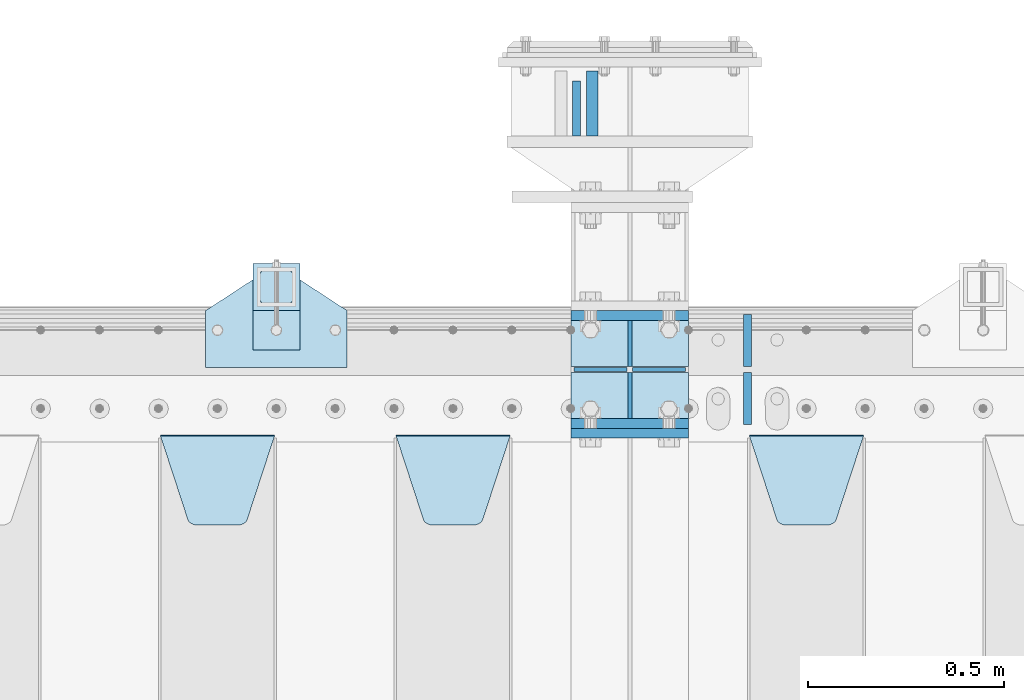
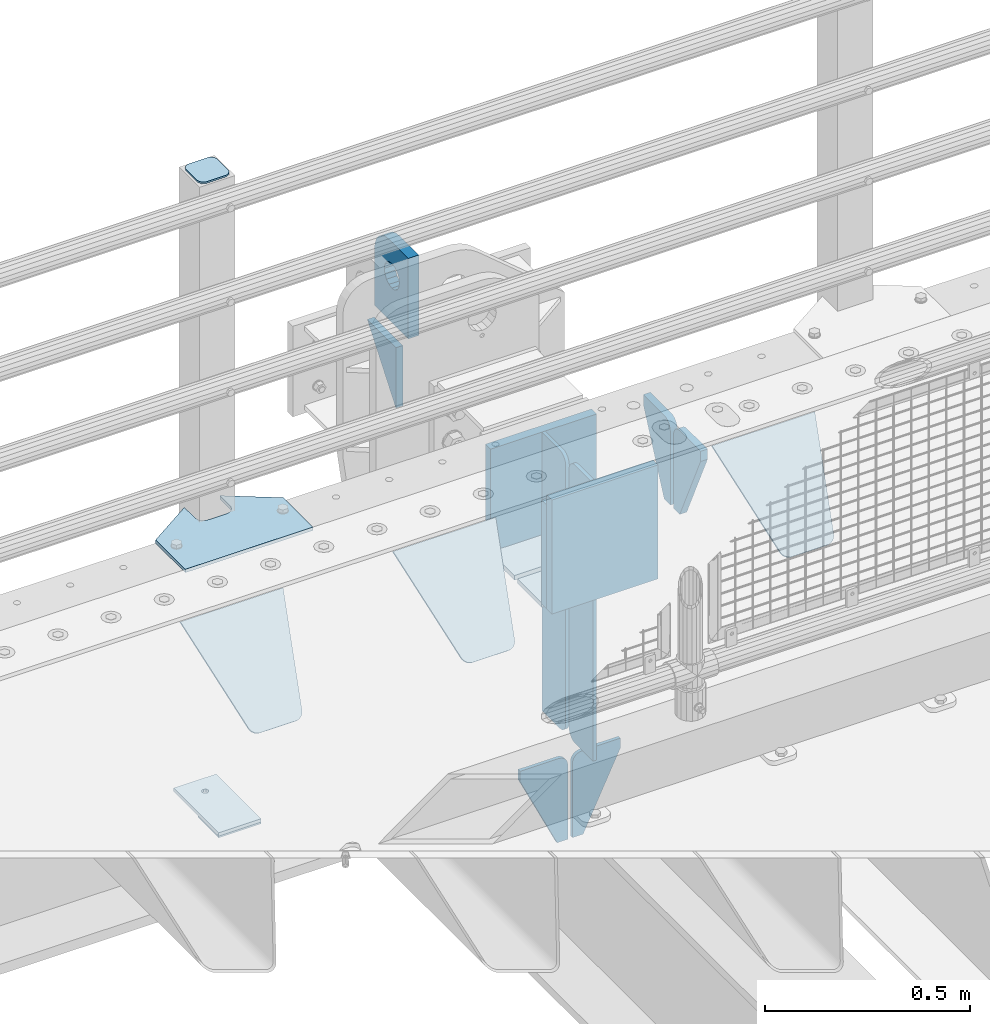
# One storey, part 231 of 257: 22 plates.
"""IFC2X3 building model written with IfcOpenShell, lengths in millimetres."""

from ifc_helpers import new_model, si_unit, frame, origin_with_axes, place, context, subcontext, project, spatial, faceted_brep, material, type_object, element, save


model = new_model("IFC2X3")

# Units and contexts
model_context = context("Model", 3, precision=1e-05, world=origin_with_axes())
body_context = subcontext(model_context, "Body", "Model", "MODEL_VIEW")
ifc_project = project(units=[si_unit("LENGTHUNIT", "METRE", prefix="MILLI"), si_unit("AREAUNIT", "SQUARE_METRE"), si_unit("VOLUMEUNIT", "CUBIC_METRE"), si_unit("MASSUNIT", "GRAM", prefix="KILO"), si_unit("TIMEUNIT", "SECOND"), si_unit("PLANEANGLEUNIT", "RADIAN"), si_unit("SOLIDANGLEUNIT", "STERADIAN"), si_unit("THERMODYNAMICTEMPERATUREUNIT", "DEGREE_CELSIUS"), si_unit("LUMINOUSINTENSITYUNIT", "LUMEN")], contexts=[model_context])

# Site, building, storey
site_placement = place(None, origin_with_axes())
site = spatial("IfcSite", under=ifc_project, at=site_placement, CompositionType="ELEMENT")
building_placement = place(site_placement, origin_with_axes())
building = spatial("IfcBuilding", under=site, at=building_placement, Name="Standard", CompositionType="ELEMENT")
storey_placement = place(building_placement, origin_with_axes())
storey = spatial("IfcBuildingStorey", under=building, at=storey_placement, Name="Undefined", CompositionType="ELEMENT", Elevation=0.0)

# Plates
ifc_material_1 = material(Name="STEEL/S355N")
plate_type_1 = type_object("IfcPlateType", PredefinedType="NOTDEFINED")
plate_1_placement = place(storey_placement, frame((54564.5000000687, 12735.0000000407, -14.0000195365101), z_axis=(0.0, 0.0, -1.0), x_axis=(0.0, -1.0, 0.0)))
element("IfcPlate", 1, at=plate_1_placement, inside=storey, type_object=plate_type_1, material=ifc_material_1, context=body_context, shape_type="Brep", body=[
    faceted_brep([(0.0, -10.0, 0.0), (140.0, -10.0, 180.0), (140.0, 10.0, 180.0), (0.0, 10.0, 0.0), (140.0, -10.0, -1.81898940354586e-12), (140.0, 10.0, -1.81898940354586e-12)], [[[0, 1, 2, 3]], [[1, 4, 5, 2]], [[4, 0, 3, 5]], [[5, 3, 2]], [[4, 1, 0]]]),
])
plate_type_2 = type_object("IfcPlateType", PredefinedType="NOTDEFINED")
plate_2_placement = place(storey_placement, frame((54604.500000067, 12595.0000000406, -1.95365428226069e-05), z_axis=(0.0, 1.0, 0.0), x_axis=(0.0, 0.0, 1.0)))
element("IfcPlate", 2, at=plate_2_placement, inside=storey, type_object=plate_type_2, material=ifc_material_1, context=body_context, shape_type="Brep", body=[
    faceted_brep([(125.840713002475, 15.0000005560505, 114.183542552877), (125.840713002475, -14.9999994439495, 114.183542852878), (113.837049096081, -14.9999995241524, 106.162951053862), (113.837049096081, 15.0000004758476, 106.162950753862), (105.816457297066, -14.9999996441911, 94.1592871474677), (105.816457297066, 15.0000003558089, 94.1592868474672), (102.999999999984, -14.9999997857813, 80.0000001499593), (102.999999999984, 15.0000002142187, 79.9999998499588), (105.816457297066, -14.9999999273787, 65.8407131524509), (105.816457297066, 15.0000000726213, 65.8407128524505), (113.837049096081, -15.0000000474101, 53.8370492460563), (113.837049096081, 14.9999999525899, 53.8370489460558), (125.840713002475, -15.0000001276203, 45.8164574470411), (125.840713002475, 14.9999998723797, 45.8164571470406), (139.999999999984, -15.0000001557855, 43.0000001499593), (139.999999999984, 14.9999998442145, 42.9999998499588), (154.159286997492, -15.0000001276203, 45.8164574470411), (154.159286997492, 14.9999998723797, 45.8164571470406), (166.162950903886, -15.0000000474101, 53.8370492460563), (166.162950903886, 14.9999999525899, 53.8370489460558), (174.183542702901, -14.9999999273787, 65.8407131524509), (174.183542702901, 15.0000000726213, 65.8407128524505), (176.999999999984, -14.9999997857813, 80.0000001499593), (176.999999999984, 15.0000002142187, 79.9999998499588), (174.183542702901, -14.9999996441911, 94.1592871474677), (174.183542702901, 15.0000003558089, 94.1592868474672), (166.162950903886, -14.9999995241524, 106.162951053862), (166.162950903886, 15.0000004758476, 106.162950753862), (154.159286997492, -14.9999994439495, 114.183542852878), (154.159286997492, 15.0000005560505, 114.183542552877), (139.999999999984, -14.9999994157843, 117.000000149959), (139.999999999984, 15.0000005842157, 116.999999849959), (-1.40620068123098e-06, -14.9999999999927, 165.000000000002), (170.002837349484, -14.9999999999927, 164.997157401463), (170.002837349484, 15.0000000000073, 164.997157401462), (-1.40620068123098e-06, 15.0000000000073, 165.000000000002), (188.120138118986, -14.9999999999927, 162.611660295068), (188.120138118986, 15.0000000000073, 162.611660295066), (205.002693976271, -14.9999999999927, 155.618342674454), (205.002693976271, 15.0000000000073, 155.618342674452), (219.499985670386, -14.9999999999927, 144.493787979865), (219.499985670386, 15.0000000000073, 144.493787979864), (230.624045898169, -14.9999999999927, 129.996116868069), (230.624045898169, 15.0000000000073, 129.996116868067), (237.616787699976, -14.9999999999927, 113.113322498937), (237.616787699976, 15.0000000000073, 113.113322498935), (240.001666876698, -15.0, 94.9959403776247), (240.001666876698, 15.0, 94.9959403776229), (240.000015258789, -14.9999999999927, -2.03726813197136e-10), (240.000015258789, 15.0000000000073, -2.05545802600682e-10), (0.0, -15.0, 0.0), (0.0, 15.0, 0.0)], [[[0, 1, 2, 3]], [[3, 2, 4, 5]], [[5, 4, 6, 7]], [[7, 6, 8, 9]], [[9, 8, 10, 11]], [[11, 10, 12, 13]], [[13, 12, 14, 15]], [[15, 14, 16, 17]], [[17, 16, 18, 19]], [[19, 18, 20, 21]], [[21, 20, 22, 23]], [[23, 22, 24, 25]], [[25, 24, 26, 27]], [[27, 26, 28, 29]], [[29, 28, 30, 31]], [[31, 30, 1, 0]], [[32, 33, 34, 35]], [[33, 36, 37, 34]], [[36, 38, 39, 37]], [[38, 40, 41, 39]], [[40, 42, 43, 41]], [[42, 44, 45, 43]], [[44, 46, 47, 45]], [[46, 48, 49, 47]], [[48, 50, 51, 49]], [[34, 37, 39, 41, 43, 45, 47, 49, 51, 35], [3, 5, 7, 9, 11, 13, 15, 17, 19, 21, 23, 25, 27, 29, 31, 0]], [[50, 32, 35, 51]], [[48, 46, 44, 42, 40, 38, 36, 33, 32, 50], [26, 24, 22, 20, 18, 16, 14, 12, 10, 8, 6, 4, 2, 1, 30, 28]]]),
])
plate_type_3 = type_object("IfcPlateType", PredefinedType="NOTDEFINED")
plate_3_placement = place(storey_placement, frame((54550.0, 11837.5, -340.000000000044), z_axis=(0.0, 0.0, 1.0), x_axis=(1.0, 0.0, 0.0)))
element("IfcPlate", 3, at=plate_3_placement, inside=storey, type_object=plate_type_3, material=ifc_material_1, context=body_context, shape_type="Brep", body=[
    faceted_brep([(0.0, -12.5, 0.0), (0.0, -12.5, 340.0), (0.0, 12.5, 340.0), (0.0, 12.5, 0.0), (300.0, -12.5, 340.0), (300.0, 12.5, 340.0), (300.0, -12.5, 0.0), (300.0, 12.5, 0.0)], [[[0, 1, 2, 3]], [[1, 4, 5, 2]], [[4, 6, 7, 5]], [[6, 0, 3, 7]], [[5, 7, 3, 2]], [[6, 4, 1, 0]]]),
])
for number, where, z_axis, x_axis in (
    (4, (54550.0, 12137.5, -340.0), (0.0, 0.0, 1.0), (1.0, 0.0, 0.0)),
    (5, (54550.0, 11862.5, -340.0), (0.0, 0.0, 1.0), (1.0, 0.0, 0.0)),
):
    element("IfcPlate", number, at=place(storey_placement, frame(where, z_axis=z_axis, x_axis=x_axis)), inside=storey, type_object=plate_type_3, material=ifc_material_1, context=body_context, shape_type="Brep", body=[
        faceted_brep([(0.0, -12.5, 0.0), (0.0, -12.5, 310.0), (0.0, 12.5, 310.0), (0.0, 12.5, 0.0), (300.0, -12.5, 310.0), (300.0, 12.5, 310.0), (300.0, -12.5, 0.0), (300.0, 12.5, 0.0)], [[[0, 1, 2, 3]], [[1, 4, 5, 2]], [[4, 6, 7, 5]], [[6, 0, 3, 7]], [[5, 7, 3, 2]], [[6, 4, 1, 0]]]),
    ])
plate_type_4 = type_object("IfcPlateType", PredefinedType="NOTDEFINED")
for number, where, z_axis, x_axis in (
    (6, (54550.0, 11992.0, -343.0), (0.0, -1.0, 0.0), (1.0, 0.0, 0.0)),
    (7, (54550.0, 12008.0, -343.0), (0.0, 1.0, 0.0), (1.0, 0.0, 0.0)),
):
    element("IfcPlate", number, at=place(storey_placement, frame(where, z_axis=z_axis, x_axis=x_axis)), inside=storey, type_object=plate_type_4, material=ifc_material_1, context=body_context, shape_type="Brep", body=[
        faceted_brep([(0.0, -7.0, 0.0), (0.0, -7.0, 117.0), (0.0, 7.0, 117.0), (0.0, 7.0, 0.0), (300.0, -7.0, 117.0), (300.0, 7.0, 117.0), (300.0, -7.0, 0.0), (300.0, 7.0, 0.0)], [[[0, 1, 2, 3]], [[1, 4, 5, 2]], [[4, 6, 7, 5]], [[6, 0, 3, 7]], [[5, 7, 3, 2]], [[6, 4, 1, 0]]]),
    ])
plate_type_5 = type_object("IfcPlateType", PredefinedType="NOTDEFINED")
for number, where, z_axis, x_axis in (
    (8, (54700.0, 11992.0, -350.0), (0.0, 0.0, -1.0), (0.0, -1.0, 0.0)),
    (9, (54700.0, 12008.0, -350.0), (0.0, 0.0, -1.0), (0.0, 1.0, 0.0)),
):
    element("IfcPlate", number, at=place(storey_placement, frame(where, z_axis=z_axis, x_axis=x_axis)), inside=storey, type_object=plate_type_5, material=ifc_material_1, context=body_context, shape_type="Brep", body=[
        faceted_brep([(0.0, -5.0, 0.0), (0.0, -5.0, 480.0), (0.0, 5.0, 480.0), (0.0, 5.0, 0.0), (0.455767409633609, -5.0, 485.209445330008), (0.455767409633609, 5.0, 485.209445330008), (1.80922137642256, -5.0, 490.26060429977), (1.80922137642256, 5.0, 490.26060429977), (4.01923788646673, -5.0, 495.0), (4.01923788646673, 5.0, 495.0), (7.01866670643085, -5.0, 499.283628290596), (7.01866670643085, 5.0, 499.283628290596), (10.716371709404, -5.0, 502.981333293569), (10.716371709404, 5.0, 502.981333293569), (15.0, -5.0, 505.980762113533), (15.0, 5.0, 505.980762113533), (19.73939570023, -5.0, 508.190778623577), (19.73939570023, 5.0, 508.190778623577), (24.7905546699922, -5.0, 509.544232590366), (24.7905546699922, 5.0, 509.544232590366), (30.0, -5.0, 510.0), (30.0, 5.0, 510.0), (117.0, -5.0, 510.0), (117.0, 5.0, 510.0), (117.0, -5.0, 0.0), (117.0, 5.0, 0.0)], [[[0, 1, 2, 3]], [[1, 4, 5, 2]], [[4, 6, 7, 5]], [[6, 8, 9, 7]], [[8, 10, 11, 9]], [[10, 12, 13, 11]], [[12, 14, 15, 13]], [[14, 16, 17, 15]], [[16, 18, 19, 17]], [[18, 20, 21, 19]], [[20, 22, 23, 21]], [[22, 24, 25, 23]], [[24, 0, 3, 25]], [[5, 7, 9, 11, 13, 15, 17, 19, 21, 23, 25, 3, 2]], [[24, 22, 20, 18, 16, 14, 12, 10, 8, 6, 4, 1, 0]]]),
    ])
for number, where, z_axis, x_axis in (
    (10, (54700.0, 12008.0, -30.0), (0.0, 0.0, -1.0), (0.0, 1.0, 0.0)),
    (11, (54700.0, 11992.0, -30.0), (0.0, 0.0, -1.0), (0.0, -1.0, 0.0)),
):
    element("IfcPlate", number, at=place(storey_placement, frame(where, z_axis=z_axis, x_axis=x_axis)), inside=storey, type_object=plate_type_5, material=ifc_material_1, context=body_context, shape_type="Brep", body=[
        faceted_brep([(0.0, -5.0, 30.0), (0.0, -5.0, 306.0), (0.0, 5.0, 306.0), (0.0, 5.0, 30.0), (117.0, -5.0, 306.0), (117.0, 5.0, 306.0), (117.0, -5.0, 0.0), (117.0, 5.0, 0.0), (30.0, -5.0, 0.0), (30.0, 5.0, 0.0), (24.7905546699922, -5.0, 0.455767409633758), (24.7905546699922, 5.0, 0.455767409633758), (19.7393957002296, -5.0, 1.80922137642275), (19.7393957002296, 5.0, 1.80922137642275), (15.0, -5.0, 4.01923788646684), (15.0, 5.0, 4.01923788646684), (10.7163717094036, -5.0, 7.01866670643066), (10.7163717094036, 5.0, 7.01866670643066), (7.01866670643085, -5.0, 10.7163717094038), (7.01866670643085, 5.0, 10.7163717094038), (4.01923788646673, -5.0, 15.0), (4.01923788646673, 5.0, 15.0), (1.80922137642301, -5.0, 19.7393957002299), (1.80922137642301, 5.0, 19.7393957002299), (0.455767409634063, -5.0, 24.7905546699921), (0.455767409634063, 5.0, 24.7905546699921)], [[[0, 1, 2, 3]], [[1, 4, 5, 2]], [[4, 6, 7, 5]], [[6, 8, 9, 7]], [[8, 10, 11, 9]], [[10, 12, 13, 11]], [[12, 14, 15, 13]], [[14, 16, 17, 15]], [[16, 18, 19, 17]], [[18, 20, 21, 19]], [[20, 22, 23, 21]], [[22, 24, 25, 23]], [[24, 0, 3, 25]], [[5, 7, 9, 11, 13, 15, 17, 19, 21, 23, 25, 3, 2]], [[24, 22, 20, 18, 16, 14, 12, 10, 8, 6, 4, 1, 0]]]),
    ])
plate_type_6 = type_object("IfcPlateType", PredefinedType="NOTDEFINED")
for number, where, z_axis, x_axis in (
    (12, (54693.499999996, 12000.0000000042, -915.000019536853), (0.0, 0.0, -1.0), (-1.0, 0.0, 0.0)),
    (13, (54706.4999999962, 12000.0000000042, -915.000019536854), (0.0, 0.0, -1.0), (1.0, 0.0, 0.0)),
):
    element("IfcPlate", number, at=place(storey_placement, frame(where, z_axis=z_axis, x_axis=x_axis)), inside=storey, type_object=plate_type_6, material=ifc_material_1, context=body_context, shape_type="Brep", body=[
        faceted_brep([(0.0, -5.0, 27.0), (0.0, -5.0, 250.0), (0.0, 5.0, 250.0), (0.0, 5.0, 27.0), (30.0, -5.0, 250.0), (30.0, 5.0, 250.0), (135.0, -5.0, 30.0), (135.0, 5.0, 30.0), (135.0, -5.0, 0.0), (135.0, 5.0, 0.0), (27.0, -5.0, 0.0), (27.0, 5.0, 0.0), (22.311499202995, -5.0, 0.410190668670339), (22.311499202995, 5.0, 0.410190668670339), (17.7654561302043, -5.0, 1.62829923878053), (17.7654561302043, 5.0, 1.62829923878053), (13.5, -5.0, 3.6173140978201), (13.5, 5.0, 3.6173140978201), (9.64473453846585, -5.0, 6.31680003578754), (9.64473453846585, 5.0, 6.31680003578754), (6.31680003579095, -5.0, 9.64473453846347), (6.31680003579095, 5.0, 9.64473453846347), (3.61731409782078, -5.0, 13.5), (3.61731409782078, 5.0, 13.5), (1.62829923877871, -5.0, 17.765456130207), (1.62829923877871, 5.0, 17.765456130207), (0.410190668670111, -5.0, 22.3114992029929), (0.410190668670111, 5.0, 22.3114992029929)], [[[0, 1, 2, 3]], [[1, 4, 5, 2]], [[4, 6, 7, 5]], [[6, 8, 9, 7]], [[8, 10, 11, 9]], [[10, 12, 13, 11]], [[12, 14, 15, 13]], [[14, 16, 17, 15]], [[16, 18, 19, 17]], [[18, 20, 21, 19]], [[20, 22, 23, 21]], [[22, 24, 25, 23]], [[24, 26, 27, 25]], [[26, 0, 3, 27]], [[5, 7, 9, 11, 13, 15, 17, 19, 21, 23, 25, 27, 3, 2]], [[26, 24, 22, 20, 18, 16, 14, 12, 10, 8, 6, 4, 1, 0]]]),
    ])
plate_type_7 = type_object("IfcPlateType", PredefinedType="NOTDEFINED")
plate_4_placement = place(storey_placement, frame((55005.0, 11831.7677669559, -1.767766952965), z_axis=(0.0, -0.707106781186548, -0.707106781186547), x_axis=(1.0, 0.0, 0.0)))
element("IfcPlate", 14, at=plate_4_placement, inside=storey, type_object=plate_type_7, material=ifc_material_1, context=body_context, shape_type="Brep", body=[
    faceted_brep([(0.0, -2.5, 0.0), (69.345504679477, -2.50000000000091, 300.17173142483), (69.345504679477, 2.5, 300.171731424831), (0.0, 2.5, 0.0), (70.927406119954, -2.50000000000091, 304.8974424154), (70.927406119954, 2.5, 304.8974424154), (73.3818627772271, -2.50000000000091, 309.234538108527), (73.3818627772271, 2.49999999999909, 309.234538108527), (76.6187032999587, -2.5, 313.023683126103), (76.6187032999587, 2.5, 313.023683126103), (80.5190132705029, -2.5, 316.125672595372), (80.5190132705029, 2.5, 316.125672595371), (84.9395038596849, -2.5, 318.426546230476), (84.9395038596849, 2.5, 318.426546230477), (89.7177759439219, -2.5, 319.841774983275), (89.7177759439219, 2.5, 319.841774983275), (94.6782862926484, -2.5, 320.319366455079), (94.6782862926484, 2.5, 320.319366455079), (195.321713707352, -2.5, 320.319366455079), (195.321713707352, 2.5, 320.319366455079), (200.282224056078, -2.5, 319.841774983275), (200.282224056078, 2.49999999999909, 319.841774983275), (205.060496140315, -2.5, 318.426546230476), (205.060496140315, 2.49999999999909, 318.426546230475), (209.480986729497, -2.5, 316.125672595371), (209.480986729497, 2.5, 316.125672595371), (213.381296700041, -2.50000000000091, 313.023683126102), (213.381296700041, 2.5, 313.023683126103), (216.618137222766, -2.50000000000091, 309.234538108527), (216.618137222766, 2.5, 309.234538108527), (219.072593880039, -2.5, 304.897442415399), (219.072593880039, 2.5, 304.897442415399), (220.654495320523, -2.50000000000091, 300.17173142483), (220.654495320523, 2.5, 300.171731424831), (290.0, -2.50000000000091, 0.0), (290.0, 2.5, 9.09494701772928e-13)], [[[0, 1, 2, 3]], [[1, 4, 5, 2]], [[4, 6, 7, 5]], [[6, 8, 9, 7]], [[8, 10, 11, 9]], [[10, 12, 13, 11]], [[12, 14, 15, 13]], [[14, 16, 17, 15]], [[16, 18, 19, 17]], [[18, 20, 21, 19]], [[20, 22, 23, 21]], [[22, 24, 25, 23]], [[24, 26, 27, 25]], [[26, 28, 29, 27]], [[28, 30, 31, 29]], [[30, 32, 33, 31]], [[32, 34, 35, 33]], [[34, 0, 3, 35]], [[5, 7, 9, 11, 13, 15, 17, 19, 21, 23, 25, 27, 29, 31, 33, 35, 3, 2]], [[34, 32, 30, 28, 26, 24, 22, 20, 18, 16, 14, 12, 10, 8, 6, 4, 1, 0]]]),
])
plate_5_placement = place(storey_placement, frame((54105.0, 11831.7677669559, -1.767766952965), z_axis=(0.0, -0.707106781186548, -0.707106781186547), x_axis=(1.0, 0.0, 0.0)))
element("IfcPlate", 15, at=plate_5_placement, inside=storey, type_object=plate_type_7, material=ifc_material_1, context=body_context, shape_type="Brep", body=[
    faceted_brep([(0.0, -2.5, 0.0), (69.345504679477, -2.50000000000091, 300.17173142483), (69.345504679477, 2.5, 300.171731424831), (0.0, 2.5, 0.0), (70.927406119954, -2.50000000000091, 304.8974424154), (70.927406119954, 2.5, 304.8974424154), (73.3818627772271, -2.50000000000091, 309.234538108527), (73.3818627772271, 2.49999999999909, 309.234538108527), (76.6187032999587, -2.5, 313.023683126103), (76.6187032999587, 2.5, 313.023683126103), (80.5190132705029, -2.5, 316.125672595372), (80.5190132705029, 2.5, 316.125672595371), (84.9395038596849, -2.5, 318.426546230476), (84.9395038596849, 2.5, 318.426546230477), (89.7177759439219, -2.5, 319.841774983275), (89.7177759439219, 2.5, 319.841774983275), (94.6782862926484, -2.5, 320.319366455079), (94.6782862926484, 2.5, 320.319366455079), (195.321713707352, -2.5, 320.319366455079), (195.321713707352, 2.5, 320.319366455079), (200.282224056078, -2.5, 319.841774983275), (200.282224056078, 2.49999999999909, 319.841774983275), (205.060496140315, -2.5, 318.426546230476), (205.060496140315, 2.49999999999909, 318.426546230475), (209.480986729497, -2.5, 316.125672595371), (209.480986729497, 2.5, 316.125672595371), (213.381296700041, -2.50000000000091, 313.023683126102), (213.381296700041, 2.5, 313.023683126103), (216.618137222766, -2.50000000000091, 309.234538108527), (216.618137222766, 2.5, 309.234538108527), (219.072593880039, -2.5, 304.897442415399), (219.072593880039, 2.5, 304.897442415399), (220.654495320523, -2.50000000000091, 300.17173142483), (220.654495320523, 2.5, 300.171731424831), (290.0, -2.50000000000091, 0.0), (290.0, 2.5, 9.09494701772928e-13)], [[[0, 1, 2, 3]], [[1, 4, 5, 2]], [[4, 6, 7, 5]], [[6, 8, 9, 7]], [[8, 10, 11, 9]], [[10, 12, 13, 11]], [[12, 14, 15, 13]], [[14, 16, 17, 15]], [[16, 18, 19, 17]], [[18, 20, 21, 19]], [[20, 22, 23, 21]], [[22, 24, 25, 23]], [[24, 26, 27, 25]], [[26, 28, 29, 27]], [[28, 30, 31, 29]], [[30, 32, 33, 31]], [[32, 34, 35, 33]], [[34, 0, 3, 35]], [[5, 7, 9, 11, 13, 15, 17, 19, 21, 23, 25, 27, 29, 31, 33, 35, 3, 2]], [[34, 32, 30, 28, 26, 24, 22, 20, 18, 16, 14, 12, 10, 8, 6, 4, 1, 0]]]),
])
plate_6_placement = place(storey_placement, frame((53505.0, 11831.7677669559, -1.767766952965), z_axis=(0.0, -0.707106781186548, -0.707106781186547), x_axis=(1.0, 0.0, 0.0)))
element("IfcPlate", 16, at=plate_6_placement, inside=storey, type_object=plate_type_7, material=ifc_material_1, context=body_context, shape_type="Brep", body=[
    faceted_brep([(0.0, -2.5, 0.0), (69.345504679477, -2.50000000000091, 300.17173142483), (69.345504679477, 2.5, 300.171731424831), (0.0, 2.5, 0.0), (70.927406119954, -2.50000000000091, 304.8974424154), (70.927406119954, 2.5, 304.8974424154), (73.3818627772271, -2.50000000000091, 309.234538108527), (73.3818627772271, 2.49999999999909, 309.234538108527), (76.6187032999587, -2.5, 313.023683126103), (76.6187032999587, 2.5, 313.023683126103), (80.5190132705029, -2.5, 316.125672595372), (80.5190132705029, 2.5, 316.125672595371), (84.9395038596849, -2.5, 318.426546230476), (84.9395038596849, 2.5, 318.426546230477), (89.7177759439219, -2.5, 319.841774983275), (89.7177759439219, 2.5, 319.841774983275), (94.6782862926484, -2.5, 320.319366455079), (94.6782862926484, 2.5, 320.319366455079), (195.321713707352, -2.5, 320.319366455079), (195.321713707352, 2.5, 320.319366455079), (200.282224056078, -2.5, 319.841774983275), (200.282224056078, 2.49999999999909, 319.841774983275), (205.060496140315, -2.5, 318.426546230476), (205.060496140315, 2.49999999999909, 318.426546230475), (209.480986729497, -2.5, 316.125672595371), (209.480986729497, 2.5, 316.125672595371), (213.381296700041, -2.50000000000091, 313.023683126102), (213.381296700041, 2.5, 313.023683126103), (216.618137222766, -2.50000000000091, 309.234538108527), (216.618137222766, 2.5, 309.234538108527), (219.072593880039, -2.5, 304.897442415399), (219.072593880039, 2.5, 304.897442415399), (220.654495320523, -2.50000000000091, 300.17173142483), (220.654495320523, 2.5, 300.171731424831), (290.0, -2.50000000000091, 0.0), (290.0, 2.5, 9.09494701772928e-13)], [[[0, 1, 2, 3]], [[1, 4, 5, 2]], [[4, 6, 7, 5]], [[6, 8, 9, 7]], [[8, 10, 11, 9]], [[10, 12, 13, 11]], [[12, 14, 15, 13]], [[14, 16, 17, 15]], [[16, 18, 19, 17]], [[18, 20, 21, 19]], [[20, 22, 23, 21]], [[22, 24, 25, 23]], [[24, 26, 27, 25]], [[26, 28, 29, 27]], [[28, 30, 31, 29]], [[30, 32, 33, 31]], [[32, 34, 35, 33]], [[34, 0, 3, 35]], [[5, 7, 9, 11, 13, 15, 17, 19, 21, 23, 25, 27, 29, 31, 33, 35, 3, 2]], [[34, 32, 30, 28, 26, 24, 22, 20, 18, 16, 14, 12, 10, 8, 6, 4, 1, 0]]]),
])
plate_type_8 = type_object("IfcPlateType", PredefinedType="NOTDEFINED")
for number, where, z_axis, x_axis in (
    (17, (55000.0, 11860.0, -30.0), (0.0, 0.0, -1.0), (0.0, 1.0, 0.0)),
    (18, (55000.0, 12140.0, -30.0), (0.0, 0.0, -1.0), (0.0, -1.0, 0.0)),
):
    element("IfcPlate", number, at=place(storey_placement, frame(where, z_axis=z_axis, x_axis=x_axis)), inside=storey, type_object=plate_type_8, material=ifc_material_1, context=body_context, shape_type="Brep", body=[
        faceted_brep([(0.0, -10.0, 0.0), (0.0, -10.0, 30.0), (0.0, 10.0, 30.0), (0.0, 10.0, 0.0), (102.0, -10.0, 250.0), (102.0, 10.0, 250.0), (132.0, -10.0, 250.0), (132.0, 10.0, 250.0), (132.0, -10.0, 30.0), (132.0, 10.0, 30.0), (131.544232590366, -10.0, 24.790554669992), (131.544232590366, 10.0, 24.790554669992), (130.190778623577, -10.0, 19.7393957002299), (130.190778623577, 10.0, 19.7393957002299), (127.980762113533, -10.0, 15.0), (127.980762113533, 10.0, 15.0), (124.981333293569, -10.0, 10.7163717094038), (124.981333293569, 10.0, 10.7163717094038), (121.283628290596, -10.0, 7.01866670643062), (121.283628290596, 10.0, 7.01866670643062), (117.0, -10.0, 4.01923788646684), (117.0, 10.0, 4.01923788646684), (112.26060429977, -10.0, 1.80922137642278), (112.26060429977, 10.0, 1.80922137642278), (107.209445330008, -10.0, 0.455767409633722), (107.209445330008, 10.0, 0.455767409633722), (102.0, -10.0, 0.0), (102.0, 10.0, 0.0)], [[[0, 1, 2, 3]], [[1, 4, 5, 2]], [[4, 6, 7, 5]], [[6, 8, 9, 7]], [[8, 10, 11, 9]], [[10, 12, 13, 11]], [[12, 14, 15, 13]], [[14, 16, 17, 15]], [[16, 18, 19, 17]], [[18, 20, 21, 19]], [[20, 22, 23, 21]], [[22, 24, 25, 23]], [[24, 26, 27, 25]], [[26, 0, 3, 27]], [[5, 7, 9, 11, 13, 15, 17, 19, 21, 23, 25, 27, 3, 2]], [[26, 24, 22, 20, 18, 16, 14, 12, 10, 8, 6, 4, 1, 0]]]),
    ])
ifc_material_2 = material(Name="STEEL/S355J2")
plate_type_9 = type_object("IfcPlateType", PredefinedType="NOTDEFINED")
plate_7_placement = place(storey_placement, frame((53620.0, 12005.0, 5.00000000004911), z_axis=(0.0, 1.0, 0.0), x_axis=(1.0, 0.0, 0.0)))
element("IfcPlate", 19, at=plate_7_placement, inside=storey, type_object=plate_type_9, material=ifc_material_2, context=body_context, shape_type="Brep", body=[
    faceted_brep([(0.0, -5.0, 0.0), (2.31396552408114e-06, -5.0, 145.0), (2.31396552408114e-06, 5.0, 145.0), (0.0, 5.0, 0.0), (130.0, -5.0, 230.0), (130.0, 5.0, 230.0), (130.0, -5.0, 180.0), (130.0, 5.0, 180.0), (130.48036798992, -5.0, 175.122741949597), (130.48036798992, 5.0, 175.122741949597), (131.903011687216, -5.0, 170.432914190873), (131.903011687216, 5.0, 170.432914190873), (134.213259692435, -5.0, 166.11074417451), (134.213259692435, 5.0, 166.11074417451), (137.322330470335, -5.0, 162.322330470337), (137.322330470335, 5.0, 162.322330470337), (141.110744174512, -5.0, 159.213259692437), (141.110744174512, 5.0, 159.213259692437), (145.432914190875, -5.0, 156.903011687218), (145.432914190875, 5.0, 156.903011687218), (150.122741949599, -5.0, 155.48036798992), (150.122741949599, 5.0, 155.48036798992), (155.0, -5.0, 155.0), (155.0, 5.0, 155.0), (205.0, -5.0, 155.0), (205.0, 5.0, 155.0), (209.877258050401, -5.0, 155.48036798992), (209.877258050401, 5.0, 155.48036798992), (214.567085809125, -5.0, 156.903011687218), (214.567085809125, 5.0, 156.903011687218), (218.889255825488, -5.0, 159.213259692437), (218.889255825488, 5.0, 159.213259692437), (222.677669529665, -5.0, 162.322330470337), (222.677669529665, 5.0, 162.322330470337), (225.786740307565, -5.0, 166.11074417451), (225.786740307565, 5.0, 166.11074417451), (228.096988312784, -5.0, 170.432914190873), (228.096988312784, 5.0, 170.432914190873), (229.51963201008, -5.0, 175.122741949597), (229.51963201008, 5.0, 175.122741949597), (230.0, -5.0, 180.0), (230.0, 5.0, 180.0), (230.0, -5.0, 230.0), (230.0, 5.0, 230.0), (360.0, -5.0, 145.0), (360.0, 5.0, 145.0), (360.0, -5.0, -7.27595761418343e-12), (360.0, 5.0, -7.27595761418343e-12)], [[[0, 1, 2, 3]], [[1, 4, 5, 2]], [[4, 6, 7, 5]], [[6, 8, 9, 7]], [[8, 10, 11, 9]], [[10, 12, 13, 11]], [[12, 14, 15, 13]], [[14, 16, 17, 15]], [[16, 18, 19, 17]], [[18, 20, 21, 19]], [[20, 22, 23, 21]], [[22, 24, 25, 23]], [[24, 26, 27, 25]], [[26, 28, 29, 27]], [[28, 30, 31, 29]], [[30, 32, 33, 31]], [[32, 34, 35, 33]], [[34, 36, 37, 35]], [[36, 38, 39, 37]], [[38, 40, 41, 39]], [[40, 42, 43, 41]], [[42, 44, 45, 43]], [[44, 46, 47, 45]], [[46, 0, 3, 47]], [[5, 7, 9, 11, 13, 15, 17, 19, 21, 23, 25, 27, 29, 31, 33, 35, 37, 39, 41, 43, 45, 47, 3, 2]], [[46, 44, 42, 40, 38, 36, 34, 32, 30, 28, 26, 24, 22, 20, 18, 16, 14, 12, 10, 8, 6, 4, 1, 0]]]),
])
plate_type_10 = type_object("IfcPlateType", PredefinedType="NOTDEFINED")
plate_8_placement = place(storey_placement, frame((53740.0000000001, 12050.0000000002, -850.000000000002), z_axis=(0.0, 1.0, 0.0), x_axis=(1.0, 0.0, 0.0)))
element("IfcPlate", 20, at=plate_8_placement, inside=storey, type_object=plate_type_10, material=ifc_material_2, context=body_context, shape_type="Brep", body=[
    faceted_brep([(66.3639610305399, -5.0, 163.636038969113), (66.3639610305399, 5.0, 163.636038969113), (59.9999999998618, 5.0, 160.999999999791), (59.9999999998618, -5.0, 160.999999999791), (53.6360389691836, 5.0, 163.636038969113), (53.6360389691836, -5.0, 163.636038969113), (50.9999999998618, 5.0, 169.999999999791), (50.9999999998618, -5.0, 169.999999999791), (53.6360389691836, 5.0, 176.363961030469), (53.6360389691836, -5.0, 176.363961030469), (59.9999999998618, 5.0, 178.999999999791), (59.9999999998618, -5.0, 178.999999999791), (66.3639610305399, 5.0, 176.363961030469), (66.3639610305399, -5.0, 176.363961030469), (68.9999999998618, 5.0, 169.999999999791), (68.9999999998618, -5.0, 169.999999999791), (120.0, -5.0, 0.0), (120.0, -5.0, 220.0), (0.0, -5.0, 220.0), (0.0, -5.0, 0.0), (0.0, 5.0, 0.0), (120.0, 5.0, 0.0), (120.0, 5.0, 220.0), (0.0, 5.0, 220.0)], [[[0, 1, 2, 3]], [[3, 2, 4, 5]], [[5, 4, 6, 7]], [[7, 6, 8, 9]], [[9, 8, 10, 11]], [[11, 10, 12, 13]], [[13, 12, 14, 15]], [[15, 14, 1, 0]], [[16, 17, 18, 19], [3, 5, 7, 9, 11, 13, 15, 0]], [[16, 19, 20, 21]], [[17, 16, 21, 22]], [[18, 17, 22, 23]], [[19, 18, 23, 20]], [[22, 21, 20, 23], [10, 8, 6, 4, 2, 1, 14, 12]]]),
])
plate_type_11 = type_object("IfcPlateType", PredefinedType="NOTDEFINED")
plate_9_placement = place(storey_placement, frame((53844.0000000001, 12166.0000000002, 1012.50000000001), z_axis=(0.0, 1.0, 0.0), x_axis=(-1.0, 0.0, 0.0)))
element("IfcPlate", 21, at=plate_9_placement, inside=storey, type_object=plate_type_11, material=ifc_material_2, context=body_context, shape_type="Brep", body=[
    faceted_brep([(0.0, -2.5, 19.0), (0.0, -2.5, 69.0), (0.0, 2.5, 69.0), (0.0, 2.5, 19.0), (0.476369668547704, -2.5, 73.2278977451697), (0.476369668547704, 2.5, 73.2278977451697), (1.88159150985302, -2.5, 77.2437910432327), (1.88159150985302, 2.5, 77.2437910432327), (4.14520183311106, -2.5, 80.8463062353167), (4.14520183311106, 2.5, 80.8463062353167), (7.15369376468152, -2.5, 83.8547981668926), (7.15369376468152, 2.5, 83.8547981668926), (10.7562089567655, -2.5, 86.1184084901452), (10.7562089567655, 2.5, 86.1184084901452), (14.7721022548285, -2.5, 87.5236303314541), (14.7721022548285, 2.5, 87.5236303314541), (19.0, -2.5, 88.0), (19.0, 2.5, 88.0), (69.0, -2.5, 88.0), (69.0, 2.5, 88.0), (73.2278977451715, -2.5, 87.5236303314541), (73.2278977451715, 2.5, 87.5236303314541), (77.2437910432345, -2.5, 86.1184084901452), (77.2437910432345, 2.5, 86.1184084901452), (80.8463062353185, -2.5, 83.8547981668926), (80.8463062353185, 2.5, 83.8547981668926), (83.8547981668889, -2.5, 80.8463062353167), (83.8547981668889, 2.5, 80.8463062353167), (86.118408490147, -2.5, 77.2437910432327), (86.118408490147, 2.5, 77.2437910432327), (87.5236303314523, -2.5, 73.2278977451697), (87.5236303314523, 2.5, 73.2278977451697), (88.0, -2.5, 69.0), (88.0, 2.5, 69.0), (88.0, -2.5, 19.0), (88.0, 2.5, 19.0), (87.5236303314523, -2.5, 14.7721022548303), (87.5236303314523, 2.5, 14.7721022548303), (86.118408490147, -2.5, 10.7562089567673), (86.118408490147, 2.5, 10.7562089567673), (83.8547981668889, -2.5, 7.15369376468334), (83.8547981668889, 2.5, 7.15369376468334), (80.8463062353185, -2.5, 4.14520183310742), (80.8463062353185, 2.5, 4.14520183310742), (77.2437910432345, -2.5, 1.88159150985484), (77.2437910432345, 2.5, 1.88159150985484), (73.2278977451715, -2.5, 0.476369668545885), (73.2278977451715, 2.5, 0.476369668545885), (69.0, -2.5, 0.0), (69.0, 2.5, 0.0), (19.0, -2.5, 0.0), (19.0, 2.5, 0.0), (14.7721022548285, -2.5, 0.476369668545885), (14.7721022548285, 2.5, 0.476369668545885), (10.7562089567655, -2.5, 1.88159150985484), (10.7562089567655, 2.5, 1.88159150985484), (7.15369376468152, -2.5, 4.14520183310742), (7.15369376468152, 2.5, 4.14520183310742), (4.14520183311106, -2.5, 7.15369376468334), (4.14520183311106, 2.5, 7.15369376468334), (1.88159150985302, -2.5, 10.7562089567673), (1.88159150985302, 2.5, 10.7562089567673), (0.476369668547704, -2.5, 14.7721022548303), (0.476369668547704, 2.5, 14.7721022548303)], [[[0, 1, 2, 3]], [[1, 4, 5, 2]], [[4, 6, 7, 5]], [[6, 8, 9, 7]], [[8, 10, 11, 9]], [[10, 12, 13, 11]], [[12, 14, 15, 13]], [[14, 16, 17, 15]], [[16, 18, 19, 17]], [[18, 20, 21, 19]], [[20, 22, 23, 21]], [[22, 24, 25, 23]], [[24, 26, 27, 25]], [[26, 28, 29, 27]], [[28, 30, 31, 29]], [[30, 32, 33, 31]], [[32, 34, 35, 33]], [[34, 36, 37, 35]], [[36, 38, 39, 37]], [[38, 40, 41, 39]], [[40, 42, 43, 41]], [[42, 44, 45, 43]], [[44, 46, 47, 45]], [[46, 48, 49, 47]], [[48, 50, 51, 49]], [[50, 52, 53, 51]], [[52, 54, 55, 53]], [[54, 56, 57, 55]], [[56, 58, 59, 57]], [[58, 60, 61, 59]], [[60, 62, 63, 61]], [[62, 0, 3, 63]], [[5, 7, 9, 11, 13, 15, 17, 19, 21, 23, 25, 27, 29, 31, 33, 35, 37, 39, 41, 43, 45, 47, 49, 51, 53, 55, 57, 59, 61, 63, 3, 2]], [[62, 60, 58, 56, 54, 52, 50, 48, 46, 44, 42, 40, 38, 36, 34, 32, 30, 28, 26, 24, 22, 20, 18, 16, 14, 12, 10, 8, 6, 4, 1, 0]]]),
])
plate_type_12 = type_object("IfcPlateType", PredefinedType="NOTDEFINED")
plate_10_placement = place(storey_placement, frame((53740.0000000001, 12050.0000000002, -857.500000000002), z_axis=(0.0, 1.0, 0.0), x_axis=(1.0, 0.0, 0.0)))
element("IfcPlate", 22, at=plate_10_placement, inside=storey, type_object=plate_type_12, material=ifc_material_2, context=body_context, shape_type="Brep", body=[
    faceted_brep([(0.0, -2.5, 0.0), (0.0, -2.5, 100.0), (0.0, 2.5, 100.0), (0.0, 2.5, 0.0), (120.0, -2.5, 100.0), (120.0, 2.5, 100.0), (120.0, -2.5, 0.0), (120.0, 2.5, 0.0)], [[[0, 1, 2, 3]], [[1, 4, 5, 2]], [[4, 6, 7, 5]], [[6, 0, 3, 7]], [[5, 7, 3, 2]], [[6, 4, 1, 0]]]),
])

save(model, "model.ifc")
